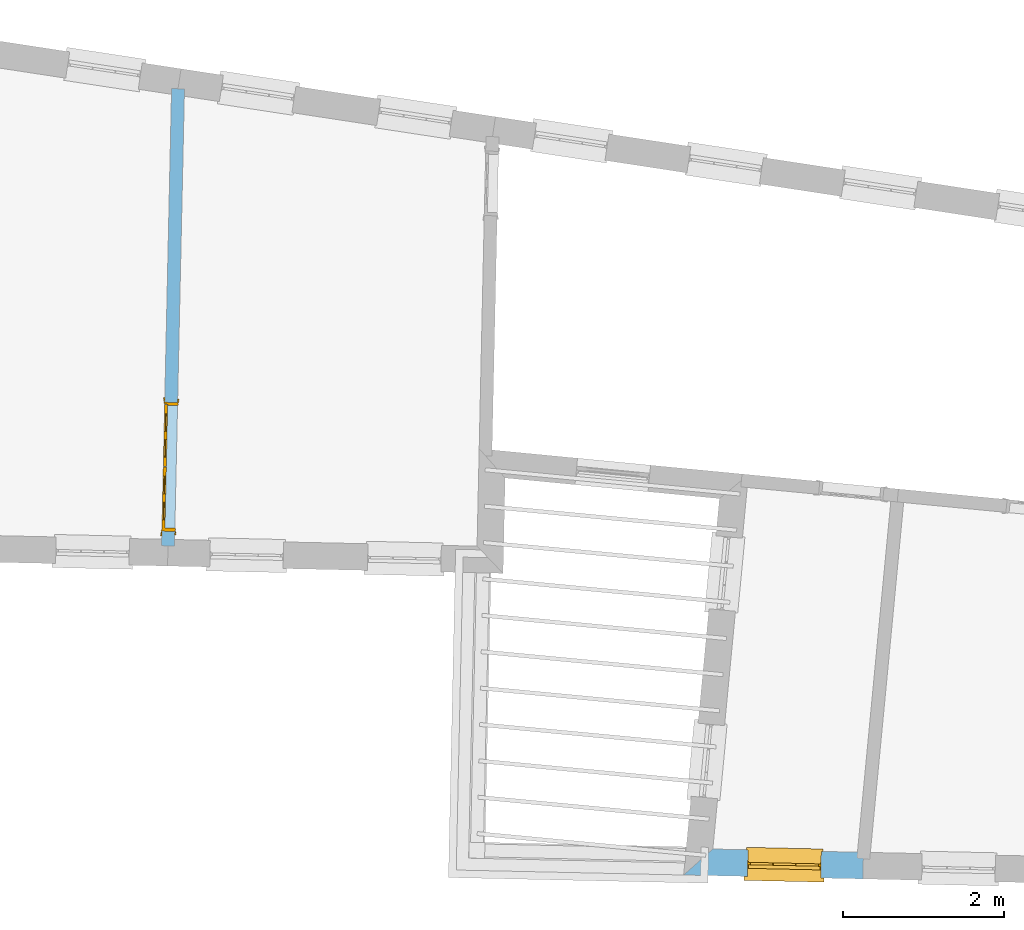
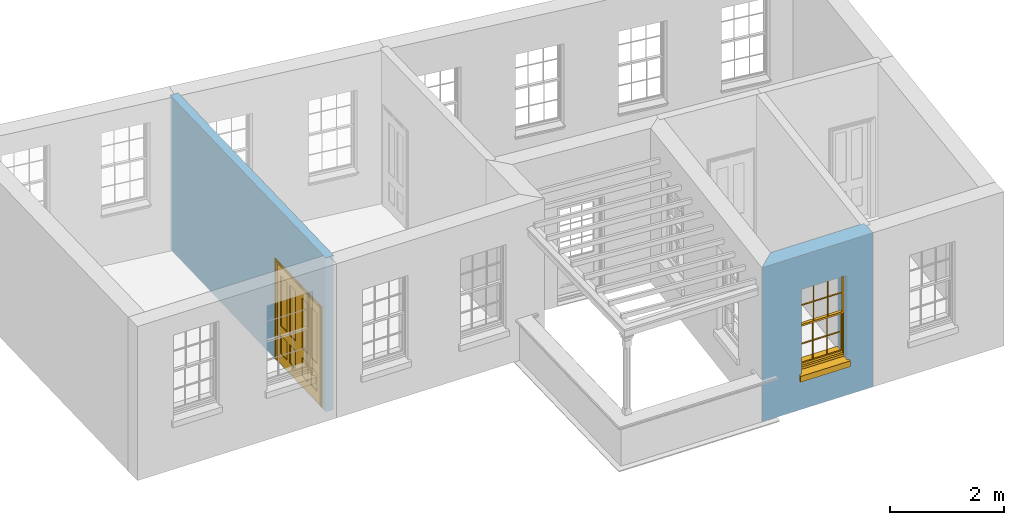
# One storey, part 4 of 12: 1 door, 1 window, 2 openings, plus 2 elements that do not belong to this part.
"""IFC2X3 building model written with IfcOpenShell, lengths in metres."""

from ifc_helpers import new_model, si_unit, frame, origin, place, context, subcontext, project, spatial, polyline, outline, extrude, faceted_brep, material, layer, layer_set, layer_usage, element, fill, save


model = new_model("IFC2X3")

# Units and contexts
model_context = context("Model", 3, world=origin())
body_context = subcontext(model_context, "Body", "Model", "MODEL_VIEW")
ifc_project = project(units=[si_unit("PLANEANGLEUNIT", "RADIAN"), si_unit("MASSUNIT", "GRAM", prefix="KILO"), si_unit("FORCEUNIT", "NEWTON", prefix="KILO"), si_unit("LENGTHUNIT", "METRE")], contexts=[model_context])

# Site, building, storey
site_placement = place(None, origin())
site = spatial("IfcSite", under=ifc_project, at=site_placement, CompositionType="ELEMENT")
building_placement = place(None, origin())
building = spatial("IfcBuilding", under=site, at=building_placement, Name="Building plot-18", CompositionType="ELEMENT")
storey_placement = place(None, frame((0.0, 0.0, 6.6)))
storey = spatial("IfcBuildingStorey", under=building, at=storey_placement, Name="Floor 1", CompositionType="ELEMENT", Elevation=6.6)

# Wall, opening, window
ifc_material_1 = material(Name="Masonry")
ifc_layer_1 = layer(ifc_material_1, 0.33, ventilated=False)
ifc_layer_set_1 = layer_set([ifc_layer_1], Name="My Wall")
ifc_layer_usage_1 = layer_usage(ifc_layer_set_1, "AXIS2", "NEGATIVE", 0.08)
wall_1_placement = place(storey_placement, origin())
wall_1 = element("IfcWallStandardCase", 1, at=wall_1_placement, inside=storey, material=ifc_layer_usage_1, Name="exterior", context=body_context, shape_type="SweptSolid", body=[
    extrude(outline(polyline([(96.7792255874086, 16.8916819408247), (96.4170785766712, 16.5695240039888), (98.6393700771944, 16.5209173697657), (98.6465862114736, 16.8508384624622), (96.7792255874086, 16.8916819408247)])), origin(), (0.0, 0.0, 1.0), 3.3),
])
opening_1_placement = place(storey_placement, frame((0.0, 0.0, 0.75)))
opening_1 = element("IfcOpeningElement", 2, at=opening_1_placement, cuts=wall_1, Name="Opening", ObjectType="Opening", context=body_context, shape_type="SweptSolid", body=[
    extrude(outline(polyline([(97.2077766371763, 16.5522296160119), (98.1175590443092, 16.5323305790603), (98.1247751785883, 16.8622516717568), (97.2149927714555, 16.8821507087084), (97.2077766371763, 16.5522296160119)])), origin(), (0.0, 0.0, 1.0), 1.82),
])
window_placement = place(storey_placement, frame((97.2132434055696, 16.8021698377517, 0.75), z_axis=(0.0, 0.0, 1.0), x_axis=(0.909782407132823, -0.0198990369516174, 0.0)))
window = element("IfcWindow", 3, at=window_placement, inside=storey, Name="toilet outside window", OverallHeight=1.82, OverallWidth=0.91, context=body_context, shape_type="Brep", held_by="IfcProductRepresentation", body=[
    faceted_brep([(0.033125, -0.105, 0.975209), (0.01, -0.105, 0.975209), (0.033125, -0.105, 1.376042), (0.876875, -0.105, 0.975209), (0.876875, -0.105, 1.376042), (0.9, -0.105, 0.975209), (0.876875, -0.105, 1.386042), (0.876875, -0.105, 1.786875), (0.9, -0.105, 1.81), (0.033125, -0.105, 1.786875), (0.033125, -0.105, 1.386042), (0.01, -0.105, 1.81), (0.876875, -0.135, 1.376042), (0.876875, -0.135, 0.975209), (0.9, -0.135, 0.937083), (0.033125, -0.135, 1.786875), (0.01, -0.135, 1.81), (0.033125, -0.135, 1.386042), (0.01, -0.135, 0.937083), (0.033125, -0.135, 0.975209), (0.033125, -0.135, 1.376042), (0.876875, -0.135, 1.786875), (0.876875, -0.135, 1.386042), (0.9, -0.135, 1.81), (0.033125, -0.105, 0.937083), (0.01, -0.105, 0.937083), (0.033125, -0.105, 0.53625), (0.876875, -0.105, 0.937083), (0.876875, -0.105, 0.53625), (0.9, -0.105, 0.937083), (0.876875, -0.105, 0.52625), (0.876875, -0.105, 0.125417), (0.9, -0.105, 0.077167), (0.033125, -0.105, 0.125417), (0.033125, -0.105, 0.52625), (0.01, -0.105, 0.077167), (-0.0425, -0.25, 0.01), (-0.0425, -0.3, 0.001667), (0.0, -0.25, 0.01), (0.9525, -0.25, 0.01), (0.91, -0.25, 0.01), (0.9525, -0.3, 0.001667), (-0.02, 0.08, 0.077167), (0.0, 0.08, 0.077167), (-0.02, 0.11, 0.077167), (0.0, -0.06, 0.077167), (0.01, -0.06, 0.077167), (0.91, -0.06, 0.077167), (0.91, 0.08, 0.077167), (0.9, -0.06, 0.077167), (0.93, 0.08, 0.077167), (0.93, 0.11, 0.077167), (0.01, -0.075, 0.975209), (0.9, -0.075, 0.975209), (0.876875, -0.075, 0.125417), (0.876875, -0.075, 0.52625), (0.9, -0.075, 0.077167), (0.876875, -0.075, 0.53625), (0.876875, -0.075, 0.937083), (0.033125, -0.075, 0.125417), (0.01, -0.075, 0.077167), (0.033125, -0.075, 0.52625), (0.033125, -0.075, 0.937083), (0.033125, -0.075, 0.53625), (-0.02, 0.08, 0.052167), (-0.02, 0.11, 0.052167), (0.93, 0.11, 0.052167), (0.93, 0.08, 0.052167), (0.91, 0.08, 0.052167), (0.0, 0.08, 0.052167), (0.91, -0.15, 0.026667), (0.0, -0.15, 0.026667), (-0.0425, -0.3, -0.123333), (0.9525, -0.3, -0.123333), (-0.0425, -0.25, -0.123333), (0.9525, -0.25, -0.123333), (0.01, -0.06, 1.81), (0.9, -0.06, 1.81), (0.0, -0.06, 1.82), (0.91, -0.06, 1.82), (0.01, -0.15, 0.077167), (0.9, -0.15, 0.077167), (0.592292, -0.105, 0.125417), (0.592292, -0.075, 0.125417), (0.317708, -0.075, 0.125417), (0.317708, -0.105, 0.125417), (0.592292, -0.105, 0.53625), (0.317708, -0.105, 0.53625), (0.317708, -0.105, 0.52625), (0.592292, -0.105, 0.52625), (0.592292, -0.075, 0.53625), (0.317708, -0.075, 0.53625), (0.592292, -0.135, 1.386042), (0.592292, -0.105, 1.386042), (0.317708, -0.105, 1.386042), (0.317708, -0.135, 1.386042), (0.317708, -0.135, 1.376042), (0.592292, -0.135, 1.376042), (0.317708, -0.105, 1.376042), (0.592292, -0.105, 1.376042), (0.602292, -0.135, 1.376042), (0.592292, -0.135, 0.975209), (0.602292, -0.135, 0.975209), (0.602292, -0.105, 0.975209), (0.592292, -0.105, 0.975209), (0.602292, -0.105, 1.376042), (0.602292, -0.075, 0.53625), (0.602292, -0.105, 0.53625), (0.317708, -0.075, 0.52625), (0.307708, -0.075, 0.125417), (0.307708, -0.075, 0.52625), (0.602292, -0.075, 0.52625), (0.602292, -0.075, 0.125417), (0.592292, -0.075, 0.52625), (0.307708, -0.075, 0.53625), (0.317708, -0.075, 0.937083), (0.307708, -0.075, 0.937083), (0.602292, -0.075, 0.937083), (0.592292, -0.075, 0.937083), (0.307708, -0.105, 0.52625), (0.307708, -0.105, 0.125417), (0.307708, -0.105, 0.53625), (0.307708, -0.105, 0.937083), (0.592292, -0.105, 0.937083), (0.317708, -0.105, 0.937083), (0.602292, -0.105, 0.937083), (0.602292, -0.105, 0.52625), (0.602292, -0.105, 0.125417), (0.307708, -0.135, 1.386042), (0.307708, -0.135, 1.376042), (0.307708, -0.135, 0.975209), (0.317708, -0.135, 0.975209), (0.317708, -0.135, 1.786875), (0.307708, -0.135, 1.786875), (0.602292, -0.135, 1.786875), (0.592292, -0.135, 1.786875), (0.602292, -0.135, 1.386042), (0.602292, -0.105, 1.386042), (0.307708, -0.105, 1.386042), (0.307708, -0.105, 1.786875), (0.317708, -0.105, 1.786875), (0.592292, -0.105, 1.786875), (0.602292, -0.105, 1.786875), (0.307708, -0.105, 1.376042), (0.317708, -0.105, 0.975209), (0.307708, -0.105, 0.975209), (0.91, -0.15, 1.82), (0.9, -0.15, 1.81), (0.01, -0.15, 1.81), (0.0, -0.15, 1.82), (0.91, -0.25, 0.0), (0.0, -0.25, 0.0), (0.91, 0.08, 0.0), (0.0, 0.08, 0.0)], [[[0, 1, 2]], [[3, 4, 5]], [[6, 7, 8]], [[9, 10, 11]], [[12, 13, 14]], [[15, 16, 17]], [[18, 19, 20]], [[21, 22, 23]], [[24, 25, 26]], [[27, 28, 29]], [[30, 31, 32]], [[33, 34, 35]], [[14, 27, 29]], [[25, 24, 18]], [[36, 37, 38]], [[39, 40, 41]], [[42, 43, 44]], [[45, 46, 43]], [[47, 48, 49]], [[50, 51, 48]], [[1, 0, 52]], [[5, 53, 3]], [[54, 55, 56]], [[57, 58, 53]], [[59, 60, 61]], [[62, 63, 52]], [[48, 43, 46, 49]], [[51, 44, 43, 48]], [[64, 42, 44, 65]], [[65, 44, 51, 66]], [[66, 51, 50, 67]], [[65, 66, 68, 69]], [[60, 56, 49, 46]], [[70, 71, 38, 40]], [[37, 41, 40, 38]], [[37, 72, 73, 41]], [[74, 75, 73, 72]], [[8, 11, 76, 77]], [[76, 78, 79, 77]], [[32, 35, 80, 81]], [[81, 80, 71, 70]], [[82, 83, 84, 85]], [[86, 87, 88, 89]], [[86, 90, 91, 87]], [[92, 93, 94, 95]], [[92, 95, 96, 97]], [[96, 98, 99, 97]], [[100, 97, 101, 102]], [[103, 104, 99, 105]], [[97, 99, 104, 101]], [[102, 103, 105, 100]], [[28, 57, 106, 107]], [[108, 84, 109, 110]], [[111, 112, 83, 113]], [[114, 110, 61, 63]], [[90, 113, 108, 91]], [[115, 91, 114, 116]], [[117, 106, 90, 118]], [[111, 106, 57, 55]], [[119, 110, 109, 120]], [[34, 61, 110, 119]], [[89, 113, 83, 82]], [[88, 108, 113, 89]], [[85, 84, 108, 88]], [[121, 114, 63, 26]], [[122, 116, 114, 121]], [[123, 118, 90, 86]], [[87, 91, 115, 124]], [[107, 106, 117, 125]], [[126, 111, 55, 30]], [[127, 112, 111, 126]], [[126, 30, 28, 107]], [[88, 119, 120, 85]], [[126, 89, 82, 127]], [[125, 123, 86, 107]], [[121, 26, 34, 119]], [[124, 122, 121, 87]], [[128, 17, 20, 129]], [[96, 129, 130, 131]], [[132, 133, 128, 95]], [[134, 135, 92, 136]], [[100, 12, 22, 136]], [[137, 6, 4, 105]], [[94, 138, 139, 140]], [[137, 93, 141, 142]], [[99, 98, 94, 93]], [[143, 2, 10, 138]], [[144, 145, 143, 98]], [[129, 143, 145, 130]], [[20, 2, 143, 129]], [[131, 144, 98, 96]], [[128, 138, 10, 17]], [[133, 139, 138, 128]], [[135, 141, 93, 92]], [[95, 94, 140, 132]], [[22, 6, 137, 136]], [[136, 137, 142, 134]], [[100, 105, 4, 12]], [[107, 86, 89, 126]], [[106, 111, 113, 90]], [[91, 108, 110, 114]], [[87, 121, 119, 88]], [[97, 100, 136, 92]], [[129, 96, 95, 128]], [[98, 143, 138, 94]], [[105, 99, 93, 137]], [[131, 101, 104, 144]], [[124, 115, 118, 123]], [[132, 140, 141, 135]], [[120, 109, 59, 33]], [[15, 9, 139, 133]], [[134, 142, 7, 21]], [[31, 54, 112, 127]], [[36, 74, 72, 37]], [[39, 41, 73, 75]], [[18, 14, 101, 131]], [[23, 16, 132, 135]], [[83, 56, 60, 84]], [[52, 53, 118, 115]], [[53, 52, 144, 104]], [[11, 8, 141, 140]], [[14, 18, 124, 123]], [[2, 1, 11, 10]], [[8, 5, 4, 6]], [[57, 53, 56, 55]], [[60, 52, 63, 61]], [[26, 25, 35, 34]], [[32, 29, 28, 30]], [[14, 23, 22, 12]], [[18, 20, 17, 16]], [[19, 0, 2, 20]], [[17, 10, 9, 15]], [[12, 4, 3, 13]], [[21, 7, 6, 22]], [[27, 58, 57, 28]], [[30, 55, 54, 31]], [[33, 59, 61, 34]], [[26, 63, 62, 24]], [[5, 8, 77, 53]], [[76, 11, 1, 52]], [[46, 45, 78, 76]], [[49, 77, 79, 47]], [[70, 146, 147, 81]], [[71, 80, 148, 149]], [[19, 130, 145, 0]], [[102, 13, 3, 103]], [[116, 122, 24, 62]], [[29, 32, 81, 14]], [[80, 35, 25, 18]], [[60, 46, 76, 52]], [[77, 49, 56, 53]], [[23, 14, 81, 147]], [[16, 148, 80, 18]], [[35, 85, 120]], [[120, 33, 35]], [[127, 82, 32]], [[32, 31, 127]], [[32, 82, 85, 35]], [[102, 101, 14]], [[14, 13, 102]], [[18, 131, 130]], [[130, 19, 18]], [[134, 21, 23]], [[23, 135, 134]], [[16, 15, 133]], [[133, 132, 16]], [[11, 140, 139]], [[139, 9, 11]], [[142, 141, 8]], [[8, 7, 142]], [[23, 147, 148, 16]], [[146, 149, 148, 147]], [[52, 115, 116]], [[116, 62, 52]], [[118, 53, 117]], [[58, 117, 53]], [[27, 125, 117, 58]], [[56, 83, 112]], [[112, 54, 56]], [[109, 84, 60]], [[60, 59, 109]], [[125, 27, 14]], [[14, 123, 125]], [[122, 124, 18]], [[18, 24, 122]], [[145, 144, 52]], [[52, 0, 145]], [[103, 3, 53]], [[53, 104, 103]], [[79, 78, 149, 146]], [[78, 45, 71, 149]], [[146, 70, 47, 79]], [[150, 75, 74, 151]], [[68, 66, 67]], [[48, 68, 67, 50]], [[69, 64, 65]], [[42, 64, 69, 43]], [[69, 68, 152, 153]], [[70, 68, 48, 47]], [[150, 152, 68, 70]], [[43, 69, 71, 45]], [[69, 153, 151, 71]], [[152, 150, 151, 153]], [[38, 151, 74, 36]], [[71, 151, 38]], [[39, 75, 150, 40]], [[40, 150, 70]]]),
])
fill(opening_1, window)

# Wall, opening, door
ifc_material_2 = material(Name="Masonry")
ifc_layer_2 = layer(ifc_material_2, 0.16, ventilated=False)
ifc_layer_set_2 = layer_set([ifc_layer_2], Name="My Wall")
ifc_layer_usage_2 = layer_usage(ifc_layer_set_2, "AXIS2", "NEGATIVE", 0.08)
wall_2_placement = place(storey_placement, origin())
wall_2 = element("IfcWallStandardCase", 4, at=wall_2_placement, inside=storey, material=ifc_layer_usage_2, Name="interior", context=body_context, shape_type="SweptSolid", body=[
    extrude(outline(polyline([(89.944084771646, 20.6525490262714), (90.1040465135594, 20.6490502944996), (90.2280074115316, 26.3165328174844), (90.0680456696182, 26.3200315492562), (89.944084771646, 20.6525490262714)])), origin(), (0.0, 0.0, 1.0), 3.3),
])
opening_2_placement = place(storey_placement, frame((0.0, 0.0, 0.0199999999999996)))
opening_2 = element("IfcOpeningElement", 5, at=opening_2_placement, cuts=wall_2, Name="Opening", ObjectType="Opening", context=body_context, shape_type="SweptSolid", body=[
    extrude(outline(polyline([(90.1079825868026, 20.8290072541523), (90.1429699045197, 22.4286246732869), (89.9830081626063, 22.4321234050586), (89.9480208448891, 20.832505985924), (90.1079825868026, 20.8290072541523)])), origin(), (0.0, 0.0, 1.0), 2.1),
])
door_placement = place(storey_placement, frame((90.0280017158459, 20.8307566200381, 0.0199999999999996), z_axis=(0.0, 0.0, 1.0), x_axis=(0.0349873177171247, 1.59961741913464, 0.0)))
door = element("IfcDoor", 6, at=door_placement, inside=storey, Name="kitchen living inside door", OverallHeight=2.1, OverallWidth=1.6, context=body_context, shape_type="Brep", held_by="IfcProductRepresentation", body=[
    faceted_brep([(0.14, 0.057, 1.895), (0.14, 0.057, 0.82), (0.363, 0.057, 0.82), (0.363, 0.057, 1.895), (0.14, 0.042, 1.895), (0.14, 0.042, 0.82), (0.363, 0.042, 0.82), (0.363, 0.042, 1.895), (0.027, 0.042, 1.895), (0.027, 0.042, 0.82), (0.363, 0.042, 0.62), (0.14, 0.042, 0.62), (0.463, 0.042, 0.82), (0.463, 0.042, 1.895), (0.363, 0.042, 2.073), (0.14, 0.042, 2.073), (0.027, 0.042, 2.073), (0.027, 0.08, 1.895), (0.027, 0.08, 0.82), (0.027, 0.042, 0.62), (0.463, 0.042, 0.62), (0.14, 0.057, 0.62), (0.363, 0.057, 0.62), (0.463, 0.057, 0.82), (0.463, 0.057, 1.895), (0.463, 0.042, 2.073), (0.14, 0.08, 2.073), (0.363, 0.08, 2.073), (0.027, 0.08, 2.073), (0.14, 0.08, 1.895), (0.14, 0.08, 0.82), (0.027, 0.08, 0.62), (0.027, 0.042, 0.225), (0.14, 0.042, 0.225), (0.363, 0.042, 0.225), (0.463, 0.042, 0.225), (0.686, 0.042, 0.62), (0.686, 0.042, 0.82), (0.14, 0.057, 0.225), (0.363, 0.057, 0.225), (0.686, 0.057, 0.82), (0.686, 0.057, 1.895), (0.686, 0.042, 1.895), (0.686, 0.042, 2.073), (0.463, 0.08, 2.073), (0.363, 0.08, 1.895), (0.14, 0.065, 1.895), (0.14, 0.065, 0.82), (0.14, 0.08, 0.62), (0.027, 0.08, 0.225), (0.027, 0.042, 0.0), (0.14, 0.042, 0.0), (0.363, 0.042, 0.0), (0.463, 0.042, 0.0), (0.463, 0.057, 0.225), (0.463, 0.057, 0.62), (0.686, 0.057, 0.62), (0.799, 0.042, 0.62), (0.799, 0.042, 0.82), (0.799, 0.042, 1.895), (0.799, 0.042, 2.073), (0.686, 0.08, 2.073), (0.463, 0.08, 1.895), (0.363, 0.065, 1.895), (0.363, 0.065, 0.82), (0.363, 0.08, 0.82), (0.363, 0.08, 0.62), (0.14, 0.08, 0.225), (0.027, 0.08, 0.0), (0.14, 0.08, 0.0), (0.363, 0.08, 0.0), (0.463, 0.08, 0.0), (0.686, 0.042, 0.0), (0.686, 0.042, 0.225), (0.686, 0.057, 0.225), (0.799, 0.042, 0.225), (0.799, 0.08, 0.62), (0.799, 0.08, 0.82), (0.799, 0.08, 1.895), (0.799, 0.08, 2.073), (0.686, 0.08, 1.895), (0.463, 0.08, 0.82), (0.463, 0.08, 0.62), (0.363, 0.065, 0.62), (0.14, 0.065, 0.62), (0.14, 0.065, 0.225), (0.363, 0.08, 0.225), (0.463, 0.08, 0.225), (0.686, 0.08, 0.0), (0.799, 0.042, 0.0), (0.799, 0.08, 0.225), (0.686, 0.08, 0.62), (0.686, 0.08, 0.82), (0.686, 0.065, 1.895), (0.463, 0.065, 1.895), (0.463, 0.065, 0.82), (0.363, 0.065, 0.225), (0.686, 0.08, 0.225), (0.799, 0.08, 0.0), (0.686, 0.065, 0.82), (0.463, 0.065, 0.62), (0.463, 0.065, 0.225), (0.686, 0.065, 0.62), (0.686, 0.065, 0.225), (1.46, 0.08, 1.895), (1.237, 0.08, 1.895), (1.237, 0.08, 2.073), (1.46, 0.08, 2.073), (1.46, 0.065, 1.895), (1.237, 0.065, 1.895), (1.137, 0.08, 1.895), (1.137, 0.08, 2.073), (1.237, 0.042, 2.073), (1.46, 0.042, 2.073), (1.573, 0.08, 1.895), (1.573, 0.08, 2.073), (1.46, 0.08, 0.82), (1.46, 0.065, 0.82), (1.237, 0.065, 0.82), (1.237, 0.08, 0.82), (1.137, 0.08, 0.82), (0.914, 0.08, 2.073), (0.914, 0.08, 1.895), (1.137, 0.042, 2.073), (1.237, 0.042, 1.895), (1.46, 0.042, 1.895), (1.573, 0.042, 2.073), (1.573, 0.08, 0.82), (1.573, 0.042, 1.895), (1.237, 0.08, 0.62), (1.137, 0.08, 0.62), (1.137, 0.065, 0.82), (1.137, 0.065, 1.895), (0.914, 0.042, 2.073), (0.914, 0.065, 1.895), (0.801, 0.08, 2.073), (0.801, 0.08, 1.895), (1.137, 0.042, 1.895), (1.237, 0.057, 1.895), (1.46, 0.057, 1.895), (1.573, 0.042, 0.82), (1.573, 0.08, 0.62), (1.46, 0.08, 0.62), (1.237, 0.08, 0.225), (1.137, 0.08, 0.225), (0.914, 0.08, 0.82), (0.914, 0.08, 0.62), (0.914, 0.065, 0.82), (0.801, 0.042, 2.073), (0.914, 0.042, 1.895), (0.801, 0.08, 0.82), (0.801, 0.042, 1.895), (1.137, 0.042, 0.82), (1.237, 0.042, 0.82), (1.237, 0.057, 0.82), (1.46, 0.057, 0.82), (1.46, 0.042, 0.82), (1.573, 0.042, 0.62), (1.573, 0.08, 0.225), (1.46, 0.08, 0.225), (1.46, 0.065, 0.62), (1.237, 0.065, 0.62), (1.237, 0.08, 0.0), (1.137, 0.08, 0.0), (1.137, 0.065, 0.225), (1.137, 0.065, 0.62), (1.237, 0.065, 0.225), (0.914, 0.065, 0.62), (0.801, 0.08, 0.62), (0.914, 0.057, 1.895), (1.137, 0.057, 1.895), (0.801, 0.042, 0.82), (1.137, 0.042, 0.62), (1.237, 0.042, 0.62), (1.137, 0.057, 0.82), (1.46, 0.042, 0.62), (1.573, 0.042, 0.225), (1.573, 0.08, 0.0), (1.46, 0.08, 0.0), (1.46, 0.065, 0.225), (1.237, 0.042, 0.0), (1.137, 0.042, 0.0), (0.914, 0.08, 0.225), (0.914, 0.08, 0.0), (0.914, 0.065, 0.225), (0.801, 0.08, 0.225), (0.801, 0.042, 0.62), (0.914, 0.042, 0.82), (0.914, 0.057, 0.82), (1.137, 0.042, 0.225), (1.237, 0.042, 0.225), (0.914, 0.042, 0.62), (1.46, 0.042, 0.225), (1.573, 0.042, 0.0), (1.46, 0.042, 0.0), (0.914, 0.042, 0.0), (0.801, 0.08, 0.0), (0.801, 0.042, 0.225), (1.237, 0.057, 0.225), (1.237, 0.057, 0.62), (1.137, 0.057, 0.62), (1.137, 0.057, 0.225), (1.46, 0.057, 0.62), (0.914, 0.057, 0.62), (1.46, 0.057, 0.225), (0.914, 0.042, 0.225), (0.801, 0.042, 0.0), (0.914, 0.057, 0.225), (0.02, 0.085, 0.0), (0.005, 0.09, 0.0), (0.005, 0.09, 2.095), (0.02, 0.085, 2.08), (0.02, 0.08, 0.0), (0.0, 0.085, 0.0), (0.0, 0.085, 2.1), (1.595, 0.09, 2.095), (1.58, 0.085, 2.08), (0.02, 0.08, 2.08), (0.0, 0.08, 0.0), (-0.032, 0.095, 0.0), (-0.032, 0.095, 2.132), (1.6, 0.085, 2.1), (1.595, 0.09, 0.0), (1.58, 0.085, 0.0), (1.58, 0.08, 2.08), (0.025, 0.08, 0.0), (0.025, 0.08, 2.075), (-0.04, 0.09, 0.0), (0.025, 0.04, 0.0), (0.0, -0.08, 0.0), (-0.04, 0.09, 2.14), (1.632, 0.095, 2.132), (1.6, 0.085, 0.0), (1.58, 0.08, 0.0), (1.575, 0.08, 2.075), (0.025, 0.04, 2.075), (-0.06, 0.08, 0.0), (0.035, -0.08, 0.0), (0.0, -0.08, 2.1), (0.0, 0.08, 2.1), (-0.04, 0.095, 0.0), (-0.04, 0.095, 2.14), (1.64, 0.09, 2.14), (1.632, 0.095, 0.0), (1.6, 0.08, 0.0), (1.575, 0.08, 0.0), (1.575, 0.04, 2.075), (0.04, 0.04, 0.0), (0.04, 0.04, 2.06), (-0.06, 0.095, 0.0), (-0.06, 0.08, 2.16), (0.015, -0.085, 0.0), (0.04, -0.08, 0.0), (-0.045, -0.08, 2.145), (-0.045, -0.08, 0.0), (1.6, -0.08, 2.1), (1.6, 0.08, 2.1), (-0.06, 0.095, 2.16), (1.64, 0.095, 2.14), (1.64, 0.09, 0.0), (1.6, -0.08, 0.0), (1.575, 0.04, 0.0), (1.56, 0.04, 2.06), (0.04, -0.08, 2.06), (1.66, 0.08, 2.16), (-0.017, -0.095, 0.0), (-0.025, -0.09, 0.0), (0.02, -0.09, 0.0), (0.035, -0.085, 0.0), (0.035, -0.08, 2.065), (1.645, -0.08, 2.145), (-0.045, -0.095, 2.145), (-0.045, -0.095, 0.0), (1.66, 0.095, 2.16), (1.64, 0.095, 0.0), (1.66, 0.08, 0.0), (1.565, -0.08, 0.0), (1.56, 0.04, 0.0), (1.56, -0.08, 2.06), (-0.017, -0.095, 2.117), (-0.025, -0.09, 2.125), (0.015, -0.085, 2.085), (0.02, -0.09, 2.08), (0.035, -0.085, 2.065), (1.565, -0.08, 2.065), (1.645, -0.08, 0.0), (1.645, -0.095, 2.145), (-0.025, -0.095, 0.0), (1.66, 0.095, 0.0), (1.585, -0.085, 0.0), (1.56, -0.08, 0.0), (1.617, -0.095, 2.117), (1.625, -0.09, 2.125), (-0.025, -0.095, 2.125), (1.585, -0.085, 2.085), (1.58, -0.09, 2.08), (1.565, -0.085, 2.065), (1.625, -0.09, 0.0), (1.645, -0.095, 0.0), (1.625, -0.095, 2.125), (1.617, -0.095, 0.0), (1.565, -0.085, 0.0), (1.58, -0.09, 0.0), (1.625, -0.095, 0.0)], [[[0, 1, 2, 3]], [[1, 0, 4, 5]], [[2, 1, 5, 6]], [[6, 7, 3, 2]], [[7, 4, 0, 3]], [[4, 8, 9, 5]], [[10, 6, 5, 11]], [[6, 12, 13, 7]], [[14, 15, 4, 7]], [[15, 16, 8, 4]], [[9, 8, 17, 18]], [[5, 9, 19, 11]], [[10, 20, 12, 6]], [[10, 11, 21, 22]], [[13, 12, 23, 24]], [[7, 13, 25, 14]], [[26, 15, 14, 27]], [[28, 16, 15, 26]], [[8, 16, 28, 17]], [[17, 29, 30, 18]], [[18, 31, 19, 9]], [[11, 19, 32, 33]], [[34, 35, 20, 10]], [[20, 36, 37, 12]], [[11, 33, 38, 21]], [[39, 22, 21, 38]], [[34, 10, 22, 39]], [[12, 37, 40, 23]], [[24, 23, 40, 41]], [[42, 13, 24, 41]], [[13, 42, 43, 25]], [[14, 25, 44, 27]], [[26, 27, 45, 29]], [[28, 26, 29, 17]], [[30, 29, 46, 47]], [[18, 30, 48, 31]], [[31, 49, 32, 19]], [[33, 32, 50, 51]], [[52, 53, 35, 34]], [[20, 35, 54, 55]], [[36, 20, 55, 56]], [[36, 57, 58, 37]], [[33, 34, 39, 38]], [[37, 42, 41, 40]], [[42, 59, 60, 43]], [[44, 25, 43, 61]], [[62, 45, 27, 44]], [[29, 45, 63, 46]], [[46, 63, 64, 47]], [[65, 30, 47, 64]], [[30, 65, 66, 48]], [[31, 48, 67, 49]], [[68, 50, 32, 49]], [[68, 69, 51, 50]], [[34, 33, 51, 52]], [[53, 52, 70, 71]], [[53, 72, 73, 35]], [[35, 73, 74, 54]], [[55, 54, 74, 56]], [[73, 36, 56, 74]], [[73, 75, 57, 36]], [[57, 76, 77, 58]], [[37, 58, 59, 42]], [[78, 79, 60, 59]], [[60, 79, 61, 43]], [[80, 62, 44, 61]], [[81, 65, 45, 62]], [[45, 65, 64, 63]], [[82, 66, 65, 81]], [[48, 66, 83, 84]], [[67, 48, 84, 85]], [[49, 67, 69, 68]], [[52, 51, 69, 70]], [[71, 70, 86, 87]], [[72, 53, 71, 88]], [[72, 89, 75, 73]], [[75, 90, 76, 57]], [[76, 91, 92, 77]], [[78, 59, 58, 77]], [[78, 80, 61, 79]], [[62, 80, 93, 94]], [[81, 62, 94, 95]], [[87, 86, 66, 82]], [[91, 82, 81, 92]], [[66, 86, 96, 83]], [[84, 83, 96, 85]], [[86, 67, 85, 96]], [[67, 86, 70, 69]], [[88, 71, 87, 97]], [[89, 72, 88, 98]], [[89, 98, 90, 75]], [[90, 97, 91, 76]], [[80, 78, 77, 92]], [[80, 92, 99, 93]], [[99, 95, 94, 93]], [[92, 81, 95, 99]], [[87, 82, 100, 101]], [[82, 91, 102, 100]], [[97, 87, 101, 103]], [[98, 88, 97, 90]], [[91, 97, 103, 102]], [[103, 101, 100, 102]], [[104, 105, 106, 107]], [[105, 104, 108, 109]], [[105, 110, 111, 106]], [[106, 112, 113, 107]], [[114, 104, 107, 115]], [[104, 116, 117, 108]], [[117, 118, 109, 108]], [[119, 105, 109, 118]], [[119, 120, 110, 105]], [[121, 111, 110, 122]], [[123, 112, 106, 111]], [[124, 125, 113, 112]], [[126, 115, 107, 113]], [[104, 114, 127, 116]], [[114, 115, 126, 128]], [[116, 119, 118, 117]], [[129, 130, 120, 119]], [[110, 120, 131, 132]], [[121, 133, 123, 111]], [[122, 110, 132, 134]], [[135, 121, 122, 136]], [[137, 124, 112, 123]], [[125, 124, 138, 139]], [[125, 128, 126, 113]], [[114, 128, 140, 127]], [[141, 142, 116, 127]], [[142, 129, 119, 116]], [[143, 144, 130, 129]], [[145, 120, 130, 146]], [[120, 145, 147, 131]], [[134, 132, 131, 147]], [[135, 148, 133, 121]], [[123, 133, 149, 137]], [[145, 122, 134, 147]], [[136, 122, 145, 150]], [[151, 148, 135, 136]], [[152, 153, 124, 137]], [[124, 153, 154, 138]], [[138, 154, 155, 139]], [[156, 125, 139, 155]], [[156, 140, 128, 125]], [[157, 141, 127, 140]], [[158, 159, 142, 141]], [[129, 142, 160, 161]], [[162, 163, 144, 143]], [[130, 144, 164, 165]], [[143, 129, 161, 166]], [[146, 130, 165, 167]], [[150, 145, 146, 168]], [[133, 148, 151, 149]], [[137, 149, 169, 170]], [[171, 151, 136, 150]], [[172, 173, 153, 152]], [[152, 137, 170, 174]], [[153, 156, 155, 154]], [[175, 157, 140, 156]], [[176, 158, 141, 157]], [[177, 178, 159, 158]], [[142, 159, 179, 160]], [[179, 166, 161, 160]], [[180, 181, 163, 162]], [[182, 144, 163, 183]], [[178, 162, 143, 159]], [[144, 182, 184, 164]], [[167, 165, 164, 184]], [[159, 143, 166, 179]], [[182, 146, 167, 184]], [[168, 146, 182, 185]], [[150, 168, 186, 171]], [[149, 151, 171, 187]], [[149, 187, 188, 169]], [[169, 188, 174, 170]], [[189, 190, 173, 172]], [[173, 175, 156, 153]], [[172, 152, 187, 191]], [[187, 152, 174, 188]], [[192, 176, 157, 175]], [[193, 177, 158, 176]], [[193, 194, 178, 177]], [[181, 180, 190, 189]], [[181, 195, 183, 163]], [[194, 180, 162, 178]], [[185, 182, 183, 196]], [[168, 185, 197, 186]], [[187, 171, 186, 191]], [[173, 190, 198, 199]], [[189, 172, 200, 201]], [[175, 173, 199, 202]], [[172, 191, 203, 200]], [[194, 193, 176, 192]], [[192, 175, 202, 204]], [[180, 194, 192, 190]], [[189, 205, 195, 181]], [[196, 183, 195, 206]], [[196, 206, 197, 185]], [[191, 186, 197, 205]], [[190, 192, 204, 198]], [[199, 198, 204, 202]], [[201, 200, 203, 207]], [[205, 189, 201, 207]], [[191, 205, 207, 203]], [[205, 197, 206, 195]], [[208, 209, 210, 211]], [[208, 212, 213, 209]], [[209, 213, 214, 210]], [[211, 210, 215, 216]], [[211, 217, 212, 208]], [[218, 213, 212]], [[213, 219, 220, 214]], [[210, 214, 221, 215]], [[216, 215, 222, 223]], [[217, 211, 216, 224]], [[225, 212, 217, 226]], [[219, 213, 218, 227]], [[218, 212, 228, 229]], [[219, 227, 230, 220]], [[214, 220, 231, 221]], [[215, 221, 232, 222]], [[222, 232, 233, 223]], [[224, 216, 223, 233]], [[226, 217, 224, 234]], [[225, 228, 212]], [[235, 228, 225, 226]], [[236, 227, 218]], [[237, 229, 228]], [[229, 238, 239, 218]], [[227, 240, 241, 230]], [[220, 230, 242, 231]], [[221, 231, 243, 232]], [[244, 233, 232]], [[234, 224, 233, 245]], [[246, 235, 226, 234]], [[247, 228, 235, 248]], [[240, 227, 236, 249]], [[239, 250, 236, 218]], [[251, 229, 237]], [[252, 237, 228, 247]], [[253, 238, 229, 254]], [[238, 255, 256, 239]], [[241, 240, 257]], [[230, 241, 258, 242]], [[231, 242, 259, 243]], [[259, 244, 232, 243]], [[260, 261, 233, 244]], [[245, 233, 261]], [[261, 246, 234, 245]], [[248, 235, 246, 262]], [[248, 263, 252, 247]], [[250, 257, 249, 236]], [[240, 249, 257]], [[256, 264, 250, 239]], [[265, 266, 229, 251]], [[267, 251, 237, 268]], [[263, 269, 237, 252]], [[270, 255, 238, 253]], [[229, 266, 254]], [[271, 253, 254, 272]], [[256, 255, 260, 244]], [[273, 241, 257]], [[273, 258, 241]], [[242, 258, 274, 259]], [[275, 244, 259]], [[260, 276, 261]], [[261, 277, 262, 246]], [[262, 278, 263, 248]], [[264, 273, 257, 250]], [[244, 275, 264, 256]], [[266, 265, 279, 280]], [[265, 251, 281, 279]], [[251, 267, 282, 281]], [[269, 283, 268, 237]], [[267, 268, 283, 282]], [[278, 284, 269, 263]], [[285, 260, 255, 270]], [[286, 270, 253, 271]], [[272, 254, 266, 287]], [[271, 272, 287]], [[273, 274, 258]], [[288, 275, 259, 274]], [[276, 260, 289]], [[277, 261, 276, 290]], [[278, 262, 277, 290]], [[275, 288, 273, 264]], [[280, 279, 291, 292]], [[287, 266, 280, 293]], [[279, 281, 294, 291]], [[281, 282, 295, 294]], [[284, 296, 283, 269]], [[282, 283, 296, 295]], [[290, 276, 284, 278]], [[285, 297, 260]], [[298, 285, 270, 286]], [[299, 286, 271]], [[271, 287, 293]], [[273, 288, 274]], [[300, 289, 260, 297]], [[301, 276, 289, 302]], [[292, 291, 300, 297]], [[293, 280, 292, 299]], [[291, 294, 289, 300]], [[294, 295, 302, 289]], [[296, 284, 276, 301]], [[295, 296, 301, 302]], [[303, 297, 285, 298]], [[299, 298, 286]], [[271, 293, 299]], [[299, 292, 297, 303]], [[299, 303, 298]]]),
])
fill(opening_2, door)

save(model, "model.ifc")
